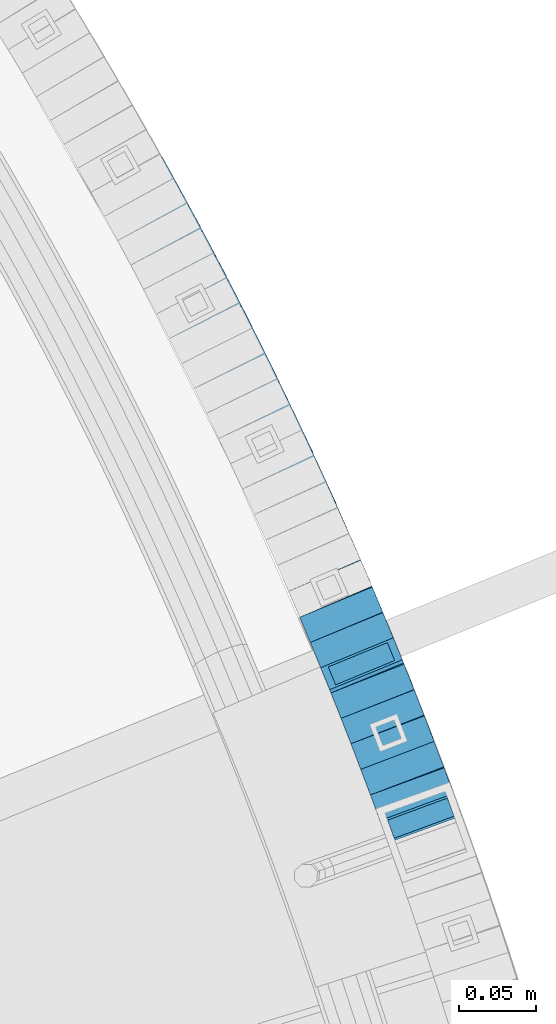
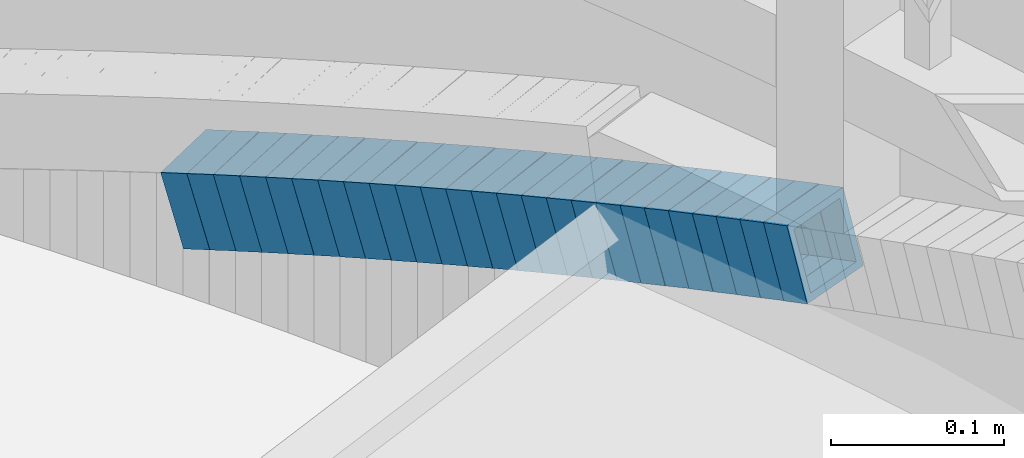
# One storey, part 807 of 975: 25 beams.
"""IFC2X3 building model written with IfcOpenShell, lengths in millimetres."""

from ifc_helpers import new_model, si_unit, frame, origin_with_axes, place, context, subcontext, project, spatial, faceted_brep, material, type_object, element, save


model = new_model("IFC2X3")

# Units and contexts
model_context = context("Model", 3, precision=1e-05, world=origin_with_axes())
body_context = subcontext(model_context, "Body", "Model", "MODEL_VIEW")
ifc_project = project(units=[si_unit("LENGTHUNIT", "METRE", prefix="MILLI"), si_unit("AREAUNIT", "SQUARE_METRE"), si_unit("VOLUMEUNIT", "CUBIC_METRE"), si_unit("MASSUNIT", "GRAM", prefix="KILO"), si_unit("TIMEUNIT", "SECOND"), si_unit("PLANEANGLEUNIT", "RADIAN"), si_unit("SOLIDANGLEUNIT", "STERADIAN"), si_unit("THERMODYNAMICTEMPERATUREUNIT", "DEGREE_CELSIUS"), si_unit("LUMINOUSINTENSITYUNIT", "LUMEN")], contexts=[model_context])

# Site, building, storey
site_placement = place(None, origin_with_axes())
site = spatial("IfcSite", under=ifc_project, at=site_placement, CompositionType="ELEMENT")
building_placement = place(site_placement, origin_with_axes())
building = spatial("IfcBuilding", under=site, at=building_placement, Name="Undefined", CompositionType="ELEMENT")
storey_placement = place(building_placement, origin_with_axes())
storey = spatial("IfcBuildingStorey", under=building, at=storey_placement, Name="Undefined", CompositionType="ELEMENT", Elevation=0.0)

# Beams
ifc_material = material()
beam_type = type_object("IfcBeamType", Name="HSS2X2X.188_TUBES", PredefinedType="NOTDEFINED")
beam_1_placement = place(storey_placement, frame((37431.361534856, 4386.02142415417, 2154.68497096555), z_axis=(-0.938632403784637, -0.344919136270336, 1.03869297163328e-10), x_axis=(-0.328827830964378, 0.894842949902667, -0.301874729967176)))
element("IfcBeam", 1, at=beam_1_placement, inside=storey, type_object=beam_type, material=ifc_material, Name="WALL", ObjectType="HSS2X2X.188_TUBES", context=body_context, shape_type="Brep", body=[
    faceted_brep([(0.0, 20.6374999999753, -20.6375000000298), (0.0, -20.6375000000153, -20.6375000000153), (18.5475065709179, -20.6374999999916, -20.6375000000335), (18.5475065709143, 20.6375000000062, -20.6375000000298), (0.0, -20.6374999999825, 20.6375000000335), (18.5475065709543, -20.6375000000007, 20.6375000000189), (0.0, 20.6375000000116, 20.6375000000189), (18.5475065709579, 20.6374999999971, 20.6375000000262), (0.0, 25.3999999999724, -25.4000000000342), (0.0, 25.400000000016, 25.4000000000196), (18.5475065709616, 25.399999999996, 25.4000000000342), (18.5475065709106, 25.4000000000087, -25.4000000000342), (0.0, -25.399999999976, 25.4000000000378), (18.5475065709616, -25.4000000000015, 25.4000000000269), (0.0, -25.400000000016, -25.4000000000196), (18.5475065709106, -25.3999999999905, -25.4000000000415)], [[[0, 1, 2, 3]], [[1, 4, 5, 2]], [[4, 6, 7, 5]], [[6, 0, 3, 7]], [[8, 9, 10, 11]], [[9, 12, 13, 10]], [[12, 14, 15, 13]], [[14, 8, 11, 15]], [[13, 15, 11, 10], [5, 7, 3, 2]], [[14, 12, 9, 8], [6, 4, 1, 0]]]),
])
beam_2_placement = place(storey_placement, frame((37425.2873895268, 4402.82980404201, 2149.12765609723), z_axis=(-0.934218386061883, -0.356701565939835, -2.52639438258484e-11), x_axis=(-0.339461138971895, 0.88906488692652, -0.30713150597462)))
element("IfcBeam", 2, at=beam_2_placement, inside=storey, type_object=beam_type, material=ifc_material, Name="WALL", ObjectType="HSS2X2X.188_TUBES", context=body_context, shape_type="Brep", body=[
    faceted_brep([(0.0, 20.6374999999753, -20.6375000000298), (0.0, -20.6375000000153, -20.6375000000153), (18.5588253938367, -20.6374999999944, -20.6374999999207), (18.5588253938367, 20.6375000000135, -20.6374999999061), (0.0, -20.6374999999825, 20.6375000000335), (18.5588253938913, -20.6375000000062, 20.6374999999498), (0.0, 20.6375000000116, 20.6375000000189), (18.5588253938949, 20.6375000000016, 20.6374999999643), (0.0, 25.3999999999724, -25.4000000000342), (0.0, 25.400000000016, 25.4000000000196), (18.5588253939022, 25.4000000000015, 25.3999999999469), (18.5588253938295, 25.400000000016, -25.399999999885), (0.0, -25.399999999976, 25.4000000000378), (18.5588253939022, -25.4000000000078, 25.3999999999323), (0.0, -25.400000000016, -25.4000000000196), (18.5588253938295, -25.3999999999942, -25.3999999998996)], [[[0, 1, 2, 3]], [[1, 4, 5, 2]], [[4, 6, 7, 5]], [[6, 0, 3, 7]], [[8, 9, 10, 11]], [[9, 12, 13, 10]], [[12, 14, 15, 13]], [[14, 8, 11, 15]], [[13, 15, 11, 10], [5, 7, 3, 2]], [[14, 12, 9, 8], [6, 4, 1, 0]]]),
])
beam_3_placement = place(storey_placement, frame((37418.977691056, 4419.31133369527, 2143.41567674985), z_axis=(-0.934933110380674, -0.354824011467542, -2.03176114155212e-10), x_axis=(-0.337841677017896, 0.890186007046939, -0.305666279016123)))
element("IfcBeam", 3, at=beam_3_placement, inside=storey, type_object=beam_type, material=ifc_material, Name="WALL", ObjectType="HSS2X2X.188_TUBES", context=body_context, shape_type="Brep", body=[
    faceted_brep([(0.0, 20.6374999999753, -20.6375000000298), (0.0, -20.6375000000153, -20.6375000000153), (18.6531498680506, -20.6374999999862, -20.6375000000007), (18.6531498680579, 20.637500000008, -20.6374999999935), (0.0, -20.6374999999825, 20.6375000000335), (18.6531498680379, -20.6374999999971, 20.6374999999789), (0.0, 20.6375000000116, 20.6375000000189), (18.6531498680451, 20.6374999999989, 20.6374999999898), (0.0, 25.3999999999724, -25.4000000000342), (0.0, 25.400000000016, 25.4000000000196), (18.653149868047, 25.399999999996, 25.3999999999869), (18.6531498680633, 25.4000000000087, -25.3999999999905), (0.0, -25.399999999976, 25.4000000000378), (18.6531498680361, -25.3999999999978, 25.3999999999796), (0.0, -25.400000000016, -25.4000000000196), (18.6531498680488, -25.3999999999851, -25.4000000000015)], [[[0, 1, 2, 3]], [[1, 4, 5, 2]], [[4, 6, 7, 5]], [[6, 0, 3, 7]], [[8, 9, 10, 11]], [[9, 12, 13, 10]], [[12, 14, 15, 13]], [[14, 8, 11, 15]], [[13, 15, 11, 10], [5, 7, 3, 2]], [[14, 12, 9, 8], [6, 4, 1, 0]]]),
])
beam_4_placement = place(storey_placement, frame((37406.2112692167, 4452.75112406194, 2131.97889944726), z_axis=(-0.930408392742472, -0.366524518571909, 1.97832378034945e-10), x_axis=(-0.349512882991962, 0.887225009979704, -0.301118790993126)))
element("IfcBeam", 4, at=beam_4_placement, inside=storey, type_object=beam_type, material=ifc_material, Name="WALL", ObjectType="HSS2X2X.188_TUBES", context=body_context, shape_type="Brep", body=[
    faceted_brep([(0.0, 20.6374999999753, -20.6375000000298), (0.0, -20.6375000000153, -20.6375000000153), (18.5970427756438, -20.6375000000062, -20.6375000000044), (18.5970427756838, 20.6374999999935, -20.6374999999498), (0.0, -20.6374999999825, 20.6375000000335), (18.5970427756511, -20.6374999999935, 20.6374999999935), (0.0, 20.6375000000116, 20.6375000000189), (18.5970427756911, 20.6375000000044, 20.637500000048), (0.0, 25.3999999999724, -25.4000000000342), (0.0, 25.400000000016, 25.4000000000196), (18.5970427756947, 25.4000000000069, 25.4000000000487), (18.5970427756874, 25.3999999999905, -25.3999999999432), (0.0, -25.399999999976, 25.4000000000378), (18.5970427756474, -25.3999999999924, 25.3999999999869), (0.0, -25.400000000016, -25.4000000000196), (18.5970427756401, -25.4000000000069, -25.4000000000051)], [[[0, 1, 2, 3]], [[1, 4, 5, 2]], [[4, 6, 7, 5]], [[6, 0, 3, 7]], [[8, 9, 10, 11]], [[9, 12, 13, 10]], [[12, 14, 15, 13]], [[14, 8, 11, 15]], [[13, 15, 11, 10], [5, 7, 3, 2]], [[14, 12, 9, 8], [6, 4, 1, 0]]]),
])
beam_5_placement = place(storey_placement, frame((37412.6820341564, 4436.10275951367, 2137.73508353568), z_axis=(-0.931577619546356, -0.363542485495637, -2.16439275391167e-10), x_axis=(-0.345865110135506, 0.886279345346861, -0.308036114120558)))
element("IfcBeam", 5, at=beam_5_placement, inside=storey, type_object=beam_type, material=ifc_material, Name="WALL", ObjectType="HSS2X2X.188_TUBES", context=body_context, shape_type="Brep", body=[
    faceted_brep([(0.0, 20.6374999999753, -20.6375000000298), (0.0, -20.6375000000153, -20.6375000000153), (18.5043238190992, -20.6375000000102, -20.6374999999534), (18.5043238191338, 20.6374999999767, -20.6374999998152), (0.0, -20.6374999999825, 20.6375000000335), (18.5043238190628, -20.6374999999972, 20.6374999999389), (0.0, 20.6375000000116, 20.6375000000189), (18.5043238190938, 20.6374999999911, 20.6375000000771), (0.0, 25.3999999999724, -25.4000000000342), (0.0, 25.400000000016, 25.4000000000196), (18.5043238190938, 25.3999999999907, 25.4000000000815), (18.5043238191411, 25.3999999999752, -25.3999999997905), (0.0, -25.399999999976, 25.4000000000378), (18.5043238190538, -25.3999999999943, 25.3999999999069), (0.0, -25.400000000016, -25.4000000000196), (18.5043238191047, -25.4000000000102, -25.3999999999578)], [[[0, 1, 2, 3]], [[1, 4, 5, 2]], [[4, 6, 7, 5]], [[6, 0, 3, 7]], [[8, 9, 10, 11]], [[9, 12, 13, 10]], [[12, 14, 15, 13]], [[14, 8, 11, 15]], [[13, 15, 11, 10], [5, 7, 3, 2]], [[14, 12, 9, 8], [6, 4, 1, 0]]]),
])
beam_6_placement = place(storey_placement, frame((37392.9927396139, 4485.89954458244, 2120.69274720963), z_axis=(-0.924912952858469, -0.380178944228409, 8.42269400891384e-11), x_axis=(-0.362326291906877, 0.881480380773022, -0.302839885922017)))
element("IfcBeam", 6, at=beam_6_placement, inside=storey, type_object=beam_type, material=ifc_material, Name="WALL", ObjectType="HSS2X2X.188_TUBES", context=body_context, shape_type="Brep", body=[
    faceted_brep([(0.0, 20.6374999999753, -20.6375000000298), (0.0, -20.6375000000153, -20.6375000000153), (18.4935123759751, -20.6375000000044, -20.6374999999862), (18.493512375946, 20.6375000000116, -20.6375000000298), (0.0, -20.6374999999825, 20.6375000000335), (18.4935123759933, -20.6375000000062, 20.6375000000335), (0.0, 20.6375000000116, 20.6375000000189), (18.4935123759642, 20.637500000008, 20.6374999999935), (0.0, 25.3999999999724, -25.4000000000342), (0.0, 25.400000000016, 25.4000000000196), (18.4935123759678, 25.4000000000106, 25.3999999999942), (18.4935123759424, 25.4000000000124, -25.4000000000342), (0.0, -25.399999999976, 25.4000000000378), (18.4935123759969, -25.4000000000069, 25.4000000000378), (0.0, -25.400000000016, -25.4000000000196), (18.4935123759751, -25.4000000000051, -25.3999999999869)], [[[0, 1, 2, 3]], [[1, 4, 5, 2]], [[4, 6, 7, 5]], [[6, 0, 3, 7]], [[8, 9, 10, 11]], [[9, 12, 13, 10]], [[12, 14, 15, 13]], [[14, 8, 11, 15]], [[13, 15, 11, 10], [5, 7, 3, 2]], [[14, 12, 9, 8], [6, 4, 1, 0]]]),
])
beam_7_placement = place(storey_placement, frame((37399.7400546087, 4469.48443496814, 2126.43264687679), z_axis=(-0.924912952858469, -0.380178944228409, 8.42269400891384e-11), x_axis=(-0.361729086010006, 0.880027479024078, -0.307739670008422)))
element("IfcBeam", 7, at=beam_7_placement, inside=storey, type_object=beam_type, material=ifc_material, Name="WALL", ObjectType="HSS2X2X.188_TUBES", context=body_context, shape_type="Brep", body=[
    faceted_brep([(0.0, 20.6374999999753, -20.6375000000298), (0.0, -20.6375000000153, -20.6375000000153), (18.5248481775634, -20.6375000000135, -20.6374999999389), (18.5248481775416, 20.6374999999935, -20.6374999999643), (0.0, -20.6374999999825, 20.6375000000335), (18.5248481775343, -20.6375000000025, 20.6375000000226), (0.0, 20.6375000000116, 20.6375000000189), (18.5248481775125, 20.6375000000044, 20.6374999999971), (0.0, 25.3999999999724, -25.4000000000342), (0.0, 25.400000000016, 25.4000000000196), (18.5248481775052, 25.4000000000051, 25.3999999999905), (18.5248481775452, 25.3999999999942, -25.3999999999651), (0.0, -25.399999999976, 25.4000000000378), (18.5248481775379, -25.4000000000015, 25.4000000000196), (0.0, -25.400000000016, -25.4000000000196), (18.5248481775707, -25.400000000016, -25.3999999999323)], [[[0, 1, 2, 3]], [[1, 4, 5, 2]], [[4, 6, 7, 5]], [[6, 0, 3, 7]], [[8, 9, 10, 11]], [[9, 12, 13, 10]], [[12, 14, 15, 13]], [[14, 8, 11, 15]], [[13, 15, 11, 10], [5, 7, 3, 2]], [[14, 12, 9, 8], [6, 4, 1, 0]]]),
])
beam_8_placement = place(storey_placement, frame((37379.5124974288, 4518.67843564499, 2109.43379788291), z_axis=(-0.920581781727087, -0.390549847205425, 9.5687028078828e-11), x_axis=(-0.371578998089543, 0.875864780211406, -0.307879741074331)))
element("IfcBeam", 8, at=beam_8_placement, inside=storey, type_object=beam_type, material=ifc_material, Name="WALL", ObjectType="HSS2X2X.188_TUBES", context=body_context, shape_type="Brep", body=[
    faceted_brep([(0.0, 20.6374999999753, -20.6375000000298), (0.0, -20.6375000000153, -20.6375000000153), (18.8433011969464, -20.6374999999898, -20.6375000000226), (18.8433011969719, 20.6375000000007, -20.6374999999862), (0.0, -20.6374999999825, 20.6375000000335), (18.8433011969828, -20.6375000000044, 20.6375000000189), (0.0, 20.6375000000116, 20.6375000000189), (18.8433011970155, 20.6374999999862, 20.6375000000517), (0.0, 25.3999999999724, -25.4000000000342), (0.0, 25.400000000016, 25.4000000000196), (18.8433011970228, 25.3999999999833, 25.4000000000597), (18.8433011969719, 25.4000000000015, -25.3999999999869), (0.0, -25.399999999976, 25.4000000000378), (18.8433011969864, -25.4000000000051, 25.4000000000196), (0.0, -25.400000000016, -25.4000000000196), (18.8433011969391, -25.3999999999869, -25.4000000000269)], [[[0, 1, 2, 3]], [[1, 4, 5, 2]], [[4, 6, 7, 5]], [[6, 0, 3, 7]], [[8, 9, 10, 11]], [[9, 12, 13, 10]], [[12, 14, 15, 13]], [[14, 8, 11, 15]], [[13, 15, 11, 10], [5, 7, 3, 2]], [[14, 12, 9, 8], [6, 4, 1, 0]]]),
])
beam_9_placement = place(storey_placement, frame((37386.321078305, 4502.23714671113, 2115.12769258672), z_axis=(-0.922909296829159, -0.38501744093782, 2.70756572717801e-12), x_axis=(-0.366407871964666, 0.878301072915186, -0.307135957970339)))
element("IfcBeam", 9, at=beam_9_placement, inside=storey, type_object=beam_type, material=ifc_material, Name="WALL", ObjectType="HSS2X2X.188_TUBES", context=body_context, shape_type="Brep", body=[
    faceted_brep([(0.0, 20.6374999999753, -20.6375000000298), (0.0, -20.6375000000153, -20.6375000000153), (18.5588253938367, -20.6374999999944, -20.6374999999207), (18.5588253938367, 20.6375000000135, -20.6374999999061), (0.0, -20.6374999999825, 20.6375000000335), (18.5588253938913, -20.6375000000062, 20.6374999999498), (0.0, 20.6375000000116, 20.6375000000189), (18.5588253938949, 20.6375000000016, 20.6374999999643), (0.0, 25.3999999999724, -25.4000000000342), (0.0, 25.400000000016, 25.4000000000196), (18.5588253939022, 25.4000000000015, 25.3999999999469), (18.5588253938295, 25.400000000016, -25.399999999885), (0.0, -25.399999999976, 25.4000000000378), (18.5588253939022, -25.4000000000078, 25.3999999999323), (0.0, -25.400000000016, -25.4000000000196), (18.5588253938295, -25.3999999999942, -25.3999999998996)], [[[0, 1, 2, 3]], [[1, 4, 5, 2]], [[4, 6, 7, 5]], [[6, 0, 3, 7]], [[8, 9, 10, 11]], [[9, 12, 13, 10]], [[12, 14, 15, 13]], [[14, 8, 11, 15]], [[13, 15, 11, 10], [5, 7, 3, 2]], [[14, 12, 9, 8], [6, 4, 1, 0]]]),
])
for number, where, z_axis, x_axis, name in (
    (10, (37365.229330194, 4552.01517060369, 2097.89610703339), (-0.91564403017333, -0.401990062076094, 0.0), (-0.383060017135246, 0.872525595308077, -0.303255847107077), "WALL"),
    (11, (37372.429330194, 4535.61517060369, 2103.59610703346), (-0.91564403017333, -0.401990062076094, 0.0), (-0.383060017135246, 0.872525595308077, -0.303255847107077), "WALL"),
):
    element("IfcBeam", number, at=place(storey_placement, frame(where, z_axis=z_axis, x_axis=x_axis)), inside=storey, type_object=beam_type, material=ifc_material, Name=name, ObjectType="HSS2X2X.188_TUBES", context=body_context, shape_type="Brep", body=[
        faceted_brep([(0.0, 20.6374999999753, -20.6375000000298), (0.0, -20.6375000000153, -20.6375000000153), (18.8047866246379, -20.6374999999916, -20.6375000000298), (18.8047866247143, 20.6374999999844, -20.6374999999643), (0.0, -20.6374999999825, 20.6375000000335), (18.8047866247107, -20.6375000000189, 20.6375000000407), (0.0, 20.6375000000116, 20.6375000000189), (18.8047866247907, 20.6374999999589, 20.6375000001026), (0.0, 25.3999999999724, -25.4000000000342), (0.0, 25.400000000016, 25.4000000000196), (18.8047866248016, 25.3999999999542, 25.4000000001142), (18.8047866247143, 25.3999999999851, -25.3999999999651), (0.0, -25.399999999976, 25.4000000000378), (18.8047866247107, -25.4000000000196, 25.4000000000415), (0.0, -25.400000000016, -25.4000000000196), (18.8047866246197, -25.3999999999887, -25.4000000000378)], [[[0, 1, 2, 3]], [[1, 4, 5, 2]], [[4, 6, 7, 5]], [[6, 0, 3, 7]], [[8, 9, 10, 11]], [[9, 12, 13, 10]], [[12, 14, 15, 13]], [[14, 8, 11, 15]], [[13, 15, 11, 10], [5, 7, 3, 2]], [[14, 12, 9, 8], [6, 4, 1, 0]]]),
    ])
beam_10_placement = place(storey_placement, frame((37358.0561707313, 4568.45229932479, 2092.23024285055), z_axis=(-0.913581686084662, -0.406655262907915, -3.83051883545705e-11), x_axis=(-0.386959013928988, 0.869332578840209, -0.307446887943492)))
element("IfcBeam", 12, at=beam_10_placement, inside=storey, type_object=beam_type, material=ifc_material, Name="WALL", ObjectType="HSS2X2X.188_TUBES", context=body_context, shape_type="Brep", body=[
    faceted_brep([(0.0, 20.6374999999753, -20.6375000000298), (0.0, -20.6375000000153, -20.6375000000153), (18.8653120832787, -20.6374999999989, -20.6374999999935), (18.8653120832823, 20.6374999999971, -20.6374999999935), (0.0, -20.6374999999825, 20.6375000000335), (18.8653120833151, -20.6375000000116, 20.6375000000298), (0.0, 20.6375000000116, 20.6375000000189), (18.8653120833151, 20.6374999999844, 20.6375000000298), (0.0, 25.3999999999724, -25.4000000000342), (0.0, 25.400000000016, 25.4000000000196), (18.8653120833187, 25.3999999999814, 25.4000000000378), (18.8653120832823, 25.3999999999942, -25.3999999999905), (0.0, -25.399999999976, 25.4000000000378), (18.8653120833187, -25.4000000000124, 25.4000000000342), (0.0, -25.400000000016, -25.4000000000196), (18.8653120832787, -25.3999999999978, -25.3999999999942)], [[[0, 1, 2, 3]], [[1, 4, 5, 2]], [[4, 6, 7, 5]], [[6, 0, 3, 7]], [[8, 9, 10, 11]], [[9, 12, 13, 10]], [[12, 14, 15, 13]], [[14, 8, 11, 15]], [[13, 15, 11, 10], [5, 7, 3, 2]], [[14, 12, 9, 8], [6, 4, 1, 0]]]),
])
beam_11_placement = place(storey_placement, frame((37350.6710153485, 4585.31778012727, 2086.40347231464), z_axis=(-0.907466907141023, -0.420123568065286, 0.0), x_axis=(-0.40021777792279, 0.864470399833495, -0.304165510941433)))
element("IfcBeam", 13, at=beam_11_placement, inside=storey, type_object=beam_type, material=ifc_material, Name="WALL", ObjectType="HSS2X2X.188_TUBES", context=body_context, shape_type="Brep", body=[
    faceted_brep([(0.0, 20.6374999999753, -20.6375000000298), (0.0, -20.6375000000153, -20.6375000000153), (18.7416648140024, -20.6375000000153, -20.6374999999825), (18.7416648139188, 20.6375000000189, -20.6375000000298), (0.0, -20.6374999999825, 20.6375000000335), (18.7416648140097, -20.6375000000189, 20.6375000000226), (0.0, 20.6375000000116, 20.6375000000189), (18.741664813926, 20.6375000000153, 20.6374999999753), (0.0, 25.3999999999724, -25.4000000000342), (0.0, 25.400000000016, 25.4000000000196), (18.7416648139224, 25.4000000000196, 25.3999999999687), (18.7416648139042, 25.4000000000233, -25.4000000000378), (0.0, -25.399999999976, 25.4000000000378), (18.7416648140133, -25.4000000000215, 25.4000000000269), (0.0, -25.400000000016, -25.4000000000196), (18.7416648140133, -25.4000000000196, -25.399999999976)], [[[0, 1, 2, 3]], [[1, 4, 5, 2]], [[4, 6, 7, 5]], [[6, 0, 3, 7]], [[8, 9, 10, 11]], [[9, 12, 13, 10]], [[12, 14, 15, 13]], [[14, 8, 11, 15]], [[13, 15, 11, 10], [5, 7, 3, 2]], [[14, 12, 9, 8], [6, 4, 1, 0]]]),
])
beam_12_placement = place(storey_placement, frame((37343.2157750118, 4601.37739180294, 2080.73134271596), z_axis=(-0.908448128220452, -0.417997605654336, 1.62363448907854e-10), x_axis=(-0.397733893080446, 0.864408326175006, -0.307580877062273)))
element("IfcBeam", 14, at=beam_12_placement, inside=storey, type_object=beam_type, material=ifc_material, Name="WALL", ObjectType="HSS2X2X.188_TUBES", context=body_context, shape_type="Brep", body=[
    faceted_brep([(0.0, 20.6374999999753, -20.6375000000298), (0.0, -20.6375000000153, -20.6375000000153), (18.8565638439322, -20.6375000000116, -20.6374999999643), (18.8565638439395, 20.637499999988, -20.6374999999534), (0.0, -20.6374999999825, 20.6375000000335), (18.856563843914, -20.6374999999953, 20.6375000000116), (0.0, 20.6375000000116, 20.6375000000189), (18.8565638439177, 20.6375000000007, 20.6375000000226), (0.0, 25.3999999999724, -25.4000000000342), (0.0, 25.400000000016, 25.4000000000196), (18.8565638439177, 25.4000000000033, 25.4000000000233), (18.8565638439468, 25.3999999999851, -25.3999999999505), (0.0, -25.399999999976, 25.4000000000378), (18.8565638439104, -25.399999999996, 25.4000000000087), (0.0, -25.400000000016, -25.4000000000196), (18.8565638439395, -25.4000000000124, -25.3999999999614)], [[[0, 1, 2, 3]], [[1, 4, 5, 2]], [[4, 6, 7, 5]], [[6, 0, 3, 7]], [[8, 9, 10, 11]], [[9, 12, 13, 10]], [[12, 14, 15, 13]], [[14, 8, 11, 15]], [[13, 15, 11, 10], [5, 7, 3, 2]], [[14, 12, 9, 8], [6, 4, 1, 0]]]),
])
for number, where, z_axis, x_axis, name in (
    (15, (37335.6240154908, 4618.14492422365, 2074.90413999574), (-0.9021342218218, -0.431455496914775, 0.0), (-0.411001450025067, 0.859366667052155, -0.304247826018466), "WALL"),
    (16, (37327.9240154908, 4634.24492422365, 2069.20413999567), (-0.9021342218218, -0.431455496914775, 0.0), (-0.411001450025067, 0.859366667052155, -0.304247826018466), "WALL"),
):
    element("IfcBeam", number, at=place(storey_placement, frame(where, z_axis=z_axis, x_axis=x_axis)), inside=storey, type_object=beam_type, material=ifc_material, Name=name, ObjectType="HSS2X2X.188_TUBES", context=body_context, shape_type="Brep", body=[
        faceted_brep([(0.0, 20.6374999999753, -20.6375000000298), (0.0, -20.6375000000153, -20.6375000000153), (18.7347271129966, -20.6375000000116, -20.6375000000262), (18.7347271130257, 20.6374999999989, -20.6374999999935), (0.0, -20.6374999999825, 20.6375000000335), (18.7347271129947, -20.6375000000116, 20.6374999999607), (0.0, 20.6375000000116, 20.6375000000189), (18.7347271130147, 20.6375000000007, 20.6374999999898), (0.0, 25.3999999999724, -25.4000000000342), (0.0, 25.400000000016, 25.4000000000196), (18.7347271130166, 25.4000000000015, 25.3999999999905), (18.7347271130257, 25.3999999999996, -25.3999999999869), (0.0, -25.399999999976, 25.4000000000378), (18.7347271129875, -25.4000000000106, 25.3999999999505), (0.0, -25.400000000016, -25.4000000000196), (18.7347271130002, -25.4000000000124, -25.4000000000233)], [[[0, 1, 2, 3]], [[1, 4, 5, 2]], [[4, 6, 7, 5]], [[6, 0, 3, 7]], [[8, 9, 10, 11]], [[9, 12, 13, 10]], [[12, 14, 15, 13]], [[14, 8, 11, 15]], [[13, 15, 11, 10], [5, 7, 3, 2]], [[14, 12, 9, 8], [6, 4, 1, 0]]]),
    ])
beam_13_placement = place(storey_placement, frame((37320.249574994, 4650.38228695842, 2063.53809115331), z_axis=(-0.899947055070276, -0.435999195034048, 0.0), x_axis=(-0.414746960994111, 0.856080264987785, -0.308401585995586)))
element("IfcBeam", 17, at=beam_13_placement, inside=storey, type_object=beam_type, material=ifc_material, Name="WALL", ObjectType="HSS2X2X.188_TUBES", context=body_context, shape_type="Brep", body=[
    faceted_brep([(0.0, 20.6374999999753, -20.6375000000298), (0.0, -20.6375000000153, -20.6375000000153), (18.8066477608099, -20.6374999999862, -20.6375000000116), (18.8066477608172, 20.6375000000062, -20.6374999999971), (0.0, -20.6374999999825, 20.6375000000335), (18.8066477608463, -20.6375000000062, 20.6375000000407), (0.0, 20.6375000000116, 20.6375000000189), (18.8066477608536, 20.6374999999844, 20.637500000048), (0.0, 25.3999999999724, -25.4000000000342), (0.0, 25.400000000016, 25.4000000000196), (18.8066477608591, 25.3999999999814, 25.400000000056), (18.8066477608154, 25.4000000000051, -25.4000000000015), (0.0, -25.399999999976, 25.4000000000378), (18.8066477608518, -25.4000000000087, 25.4000000000451), (0.0, -25.400000000016, -25.4000000000196), (18.8066477608081, -25.3999999999851, -25.4000000000196)], [[[0, 1, 2, 3]], [[1, 4, 5, 2]], [[4, 6, 7, 5]], [[6, 0, 3, 7]], [[8, 9, 10, 11]], [[9, 12, 13, 10]], [[12, 14, 15, 13]], [[14, 8, 11, 15]], [[13, 15, 11, 10], [5, 7, 3, 2]], [[14, 12, 9, 8], [6, 4, 1, 0]]]),
])
for number, where, z_axis, x_axis, name in (
    (18, (37312.342672556, 4666.91946160279, 2057.69888891501), (-0.894427190799916, -0.447213595899958, 0.0), (-0.426104957099952, 0.852209914200195, -0.303599782071307), "WALL"),
    (19, (37304.342672556, 4682.91946160279, 2051.99888891494), (-0.894427190799916, -0.447213595899958, 0.0), (-0.426104957099952, 0.852209914200195, -0.303599782071307), "WALL"),
):
    element("IfcBeam", number, at=place(storey_placement, frame(where, z_axis=z_axis, x_axis=x_axis)), inside=storey, type_object=beam_type, material=ifc_material, Name=name, ObjectType="HSS2X2X.188_TUBES", context=body_context, shape_type="Brep", body=[
        faceted_brep([(0.0, 20.6374999999753, -20.6375000000298), (0.0, -20.6375000000153, -20.6375000000153), (18.767258723612, -20.6375000000025, -20.6374999999862), (18.7672587236229, 20.6374999999953, -20.637499999968), (0.0, -20.6374999999825, 20.6375000000335), (18.767258723612, -20.6375000000135, 20.6375000000153), (0.0, 20.6375000000116, 20.6375000000189), (18.7672587236266, 20.6374999999844, 20.6375000000371), (0.0, 25.3999999999724, -25.4000000000342), (0.0, 25.400000000016, 25.4000000000196), (18.7672587236302, 25.3999999999814, 25.4000000000342), (18.7672587236229, 25.399999999996, -25.3999999999687), (0.0, -25.399999999976, 25.4000000000378), (18.7672587236157, -25.4000000000142, 25.400000000016), (0.0, -25.400000000016, -25.4000000000196), (18.767258723612, -25.4000000000015, -25.3999999999905)], [[[0, 1, 2, 3]], [[1, 4, 5, 2]], [[4, 6, 7, 5]], [[6, 0, 3, 7]], [[8, 9, 10, 11]], [[9, 12, 13, 10]], [[12, 14, 15, 13]], [[14, 8, 11, 15]], [[13, 15, 11, 10], [5, 7, 3, 2]], [[14, 12, 9, 8], [6, 4, 1, 0]]]),
    ])
beam_14_placement = place(storey_placement, frame((37296.3407630169, 4699.13777709424, 2046.33809115311), z_axis=(-0.88876758866203, -0.458358127825701, 0.0), x_axis=(-0.436016035805845, 0.84544572762388, -0.30840158586279)))
element("IfcBeam", 20, at=beam_14_placement, inside=storey, type_object=beam_type, material=ifc_material, Name="WALL", ObjectType="HSS2X2X.188_TUBES", context=body_context, shape_type="Brep", body=[
    faceted_brep([(0.0, 20.6374999999753, -20.6375000000298), (0.0, -20.6375000000153, -20.6375000000153), (18.8066477608099, -20.6374999999862, -20.6375000000116), (18.8066477608172, 20.6375000000062, -20.6374999999971), (0.0, -20.6374999999825, 20.6375000000335), (18.8066477608463, -20.6375000000062, 20.6375000000407), (0.0, 20.6375000000116, 20.6375000000189), (18.8066477608536, 20.6374999999844, 20.637500000048), (0.0, 25.3999999999724, -25.4000000000342), (0.0, 25.400000000016, 25.4000000000196), (18.8066477608591, 25.3999999999814, 25.400000000056), (18.8066477608154, 25.4000000000051, -25.4000000000015), (0.0, -25.399999999976, 25.4000000000378), (18.8066477608518, -25.4000000000087, 25.4000000000451), (0.0, -25.400000000016, -25.4000000000196), (18.8066477608081, -25.3999999999851, -25.4000000000196)], [[[0, 1, 2, 3]], [[1, 4, 5, 2]], [[4, 6, 7, 5]], [[6, 0, 3, 7]], [[8, 9, 10, 11]], [[9, 12, 13, 10]], [[12, 14, 15, 13]], [[14, 8, 11, 15]], [[13, 15, 11, 10], [5, 7, 3, 2]], [[14, 12, 9, 8], [6, 4, 1, 0]]]),
])
beam_15_placement = place(storey_placement, frame((37288.088268402, 4715.18289466313, 2040.50986310556), z_axis=(-0.887584423832732, -0.460645080913188, 0.0), x_axis=(-0.438703447907344, 0.845306642821126, -0.304952396935466)))
element("IfcBeam", 21, at=beam_15_placement, inside=storey, type_object=beam_type, material=ifc_material, Name="WALL", ObjectType="HSS2X2X.188_TUBES", context=body_context, shape_type="Brep", body=[
    faceted_brep([(0.0, 20.6374999999753, -20.6375000000298), (0.0, -20.6375000000153, -20.6375000000153), (18.6895692834223, -20.637499999988, -20.6374999999862), (18.6895692834369, 20.6374999999953, -20.6374999999534), (0.0, -20.6374999999825, 20.6375000000335), (18.6895692833914, -20.637499999988, 20.6374999999789), (0.0, 20.6375000000116, 20.6375000000189), (18.6895692834078, 20.6374999999953, 20.637500000008), (0.0, 25.3999999999724, -25.4000000000342), (0.0, 25.400000000016, 25.4000000000196), (18.6895692834059, 25.3999999999924, 25.4000000000087), (18.6895692834423, 25.3999999999942, -25.3999999999432), (0.0, -25.399999999976, 25.4000000000378), (18.6895692833878, -25.3999999999869, 25.3999999999687), (0.0, -25.400000000016, -25.4000000000196), (18.6895692834241, -25.3999999999869, -25.3999999999833)], [[[0, 1, 2, 3]], [[1, 4, 5, 2]], [[4, 6, 7, 5]], [[6, 0, 3, 7]], [[8, 9, 10, 11]], [[9, 12, 13, 10]], [[12, 14, 15, 13]], [[14, 8, 11, 15]], [[13, 15, 11, 10], [5, 7, 3, 2]], [[14, 12, 9, 8], [6, 4, 1, 0]]]),
])
beam_16_placement = place(storey_placement, frame((37279.8219597599, 4731.27397215604, 2034.79819223104), z_axis=(-0.882970965859413, -0.469427601925255, 0.0), x_axis=(-0.447283330194436, 0.841318645365556, -0.303513689131876)))
element("IfcBeam", 22, at=beam_16_placement, inside=storey, type_object=beam_type, material=ifc_material, Name="WALL", ObjectType="HSS2X2X.188_TUBES", context=body_context, shape_type="Brep", body=[
    faceted_brep([(0.0, 20.6374999999753, -20.6375000000298), (0.0, -20.6375000000153, -20.6375000000153), (18.7771137292038, -20.637500000008, -20.6374999999862), (18.777113729182, 20.6375000000062, -20.6375000000189), (0.0, -20.6374999999825, 20.6375000000335), (18.7771137291729, -20.6374999999916, 20.6374999999753), (0.0, 20.6375000000116, 20.6375000000189), (18.7771137291529, 20.6375000000207, 20.6374999999389), (0.0, 25.3999999999724, -25.4000000000342), (0.0, 25.400000000016, 25.4000000000196), (18.7771137291475, 25.4000000000251, 25.3999999999287), (18.7771137291857, 25.4000000000051, -25.4000000000196), (0.0, -25.399999999976, 25.4000000000378), (18.7771137291711, -25.3999999999905, 25.3999999999724), (0.0, -25.400000000016, -25.4000000000196), (18.7771137292129, -25.4000000000124, -25.3999999999724)], [[[0, 1, 2, 3]], [[1, 4, 5, 2]], [[4, 6, 7, 5]], [[6, 0, 3, 7]], [[8, 9, 10, 11]], [[9, 12, 13, 10]], [[12, 14, 15, 13]], [[14, 8, 11, 15]], [[13, 15, 11, 10], [5, 7, 3, 2]], [[14, 12, 9, 8], [6, 4, 1, 0]]]),
])
beam_17_placement = place(storey_placement, frame((37271.4247312034, 4747.11206185026, 2029.10925997694), z_axis=(-0.881730316985493, -0.471753800311838, 9.0209823611076e-11), x_axis=(-0.449294234130402, 0.839752318243507, -0.304878230088394)))
element("IfcBeam", 23, at=beam_17_placement, inside=storey, type_object=beam_type, material=ifc_material, Name="WALL", ObjectType="HSS2X2X.188_TUBES", context=body_context, shape_type="Brep", body=[
    faceted_brep([(0.0, 20.6374999999753, -20.6375000000298), (0.0, -20.6375000000153, -20.6375000000153), (18.6959888745805, -20.6374999999771, -20.6375000000407), (18.6959888746751, 20.637499999988, -20.6374999999716), (0.0, -20.6374999999825, 20.6375000000335), (18.6959888746969, -20.6375000000135, 20.6375000000371), (0.0, 20.6375000000116, 20.6375000000189), (18.6959888747988, 20.6374999999498, 20.6375000001062), (0.0, 25.3999999999724, -25.4000000000342), (0.0, 25.400000000016, 25.4000000000196), (18.695988874817, 25.3999999999414, 25.4000000001215), (18.6959888746678, 25.3999999999887, -25.399999999976), (0.0, -25.399999999976, 25.4000000000378), (18.6959888747042, -25.4000000000124, 25.4000000000378), (0.0, -25.400000000016, -25.4000000000196), (18.695988874555, -25.3999999999687, -25.4000000000597)], [[[0, 1, 2, 3]], [[1, 4, 5, 2]], [[4, 6, 7, 5]], [[6, 0, 3, 7]], [[8, 9, 10, 11]], [[9, 12, 13, 10]], [[12, 14, 15, 13]], [[14, 8, 11, 15]], [[13, 15, 11, 10], [5, 7, 3, 2]], [[14, 12, 9, 8], [6, 4, 1, 0]]]),
])
beam_18_placement = place(storey_placement, frame((37263.0135573711, 4762.9938176347, 2023.43665674436), z_axis=(-0.877040228787681, -0.4804169408837, 0.0), x_axis=(-0.45702675003502, 0.834339532064126, -0.308227343023689)))
element("IfcBeam", 24, at=beam_18_placement, inside=storey, type_object=beam_type, material=ifc_material, Name="WALL", ObjectType="HSS2X2X.188_TUBES", context=body_context, shape_type="Brep", body=[
    faceted_brep([(0.0, 20.6374999999753, -20.6375000000298), (0.0, -20.6375000000153, -20.6375000000153), (18.8225928075335, -20.6374999999935, -20.6375000000298), (18.8225928075699, 20.6374999999898, -20.6374999999825), (0.0, -20.6374999999825, 20.6375000000335), (18.8225928075772, -20.637500000008, 20.6375000000226), (0.0, 20.6375000000116, 20.6375000000189), (18.8225928076135, 20.6374999999753, 20.6375000000698), (0.0, 25.3999999999724, -25.4000000000342), (0.0, 25.400000000016, 25.4000000000196), (18.8225928076281, 25.3999999999705, 25.4000000000815), (18.8225928075663, 25.3999999999905, -25.3999999999796), (0.0, -25.399999999976, 25.4000000000378), (18.8225928075808, -25.4000000000087, 25.4000000000233), (0.0, -25.400000000016, -25.4000000000196), (18.8225928075226, -25.3999999999905, -25.4000000000378)], [[[0, 1, 2, 3]], [[1, 4, 5, 2]], [[4, 6, 7, 5]], [[6, 0, 3, 7]], [[8, 9, 10, 11]], [[9, 12, 13, 10]], [[12, 14, 15, 13]], [[14, 8, 11, 15]], [[13, 15, 11, 10], [5, 7, 3, 2]], [[14, 12, 9, 8], [6, 4, 1, 0]]]),
])
beam_19_placement = place(storey_placement, frame((37254.3565591379, 4778.84113567142, 2017.60830330258), z_axis=(-0.875741388878296, -0.482780508932904, 0.0), x_axis=(-0.459814159924528, 0.834081498863322, -0.304760547950051)))
element("IfcBeam", 25, at=beam_19_placement, inside=storey, type_object=beam_type, material=ifc_material, Name="WALL", ObjectType="HSS2X2X.188_TUBES", context=body_context, shape_type="Brep", body=[
    faceted_brep([(0.0, 20.6374999999753, -20.6375000000298), (0.0, -20.6375000000153, -20.6375000000153), (18.6959888745805, -20.6374999999771, -20.6375000000407), (18.6959888746751, 20.637499999988, -20.6374999999716), (0.0, -20.6374999999825, 20.6375000000335), (18.6959888746969, -20.6375000000135, 20.6375000000371), (0.0, 20.6375000000116, 20.6375000000189), (18.6959888747988, 20.6374999999498, 20.6375000001062), (0.0, 25.3999999999724, -25.4000000000342), (0.0, 25.400000000016, 25.4000000000196), (18.695988874817, 25.3999999999414, 25.4000000001215), (18.6959888746678, 25.3999999999887, -25.399999999976), (0.0, -25.399999999976, 25.4000000000378), (18.6959888747042, -25.4000000000124, 25.4000000000378), (0.0, -25.400000000016, -25.4000000000196), (18.695988874555, -25.3999999999687, -25.4000000000597)], [[[0, 1, 2, 3]], [[1, 4, 5, 2]], [[4, 6, 7, 5]], [[6, 0, 3, 7]], [[8, 9, 10, 11]], [[9, 12, 13, 10]], [[12, 14, 15, 13]], [[14, 8, 11, 15]], [[13, 15, 11, 10], [5, 7, 3, 2]], [[14, 12, 9, 8], [6, 4, 1, 0]]]),
])

save(model, "model.ifc")
